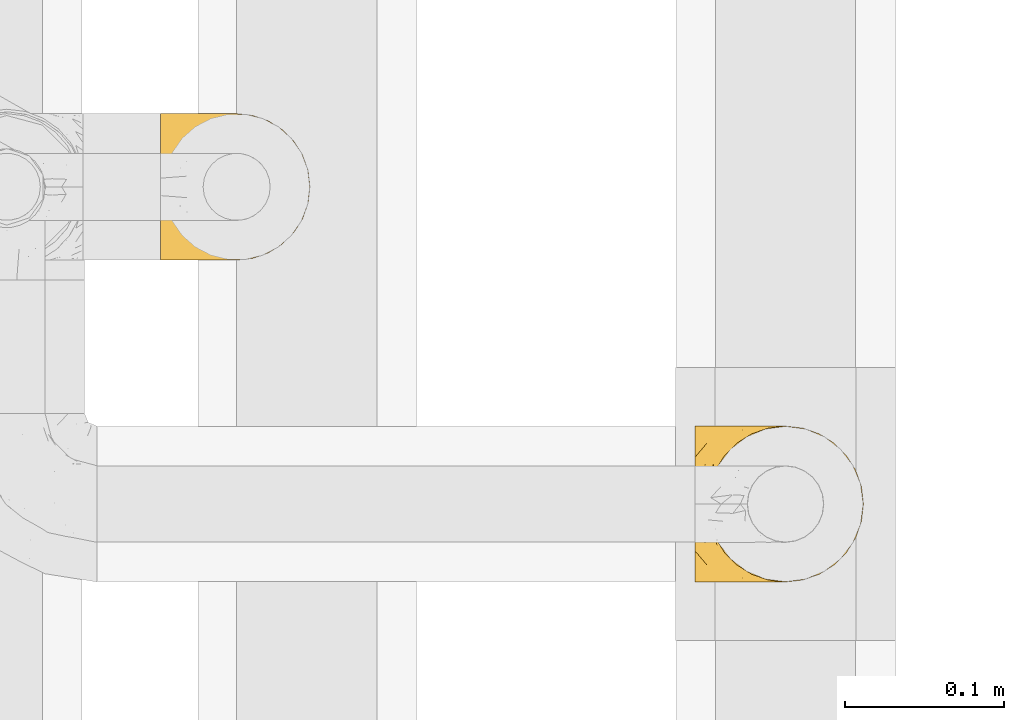
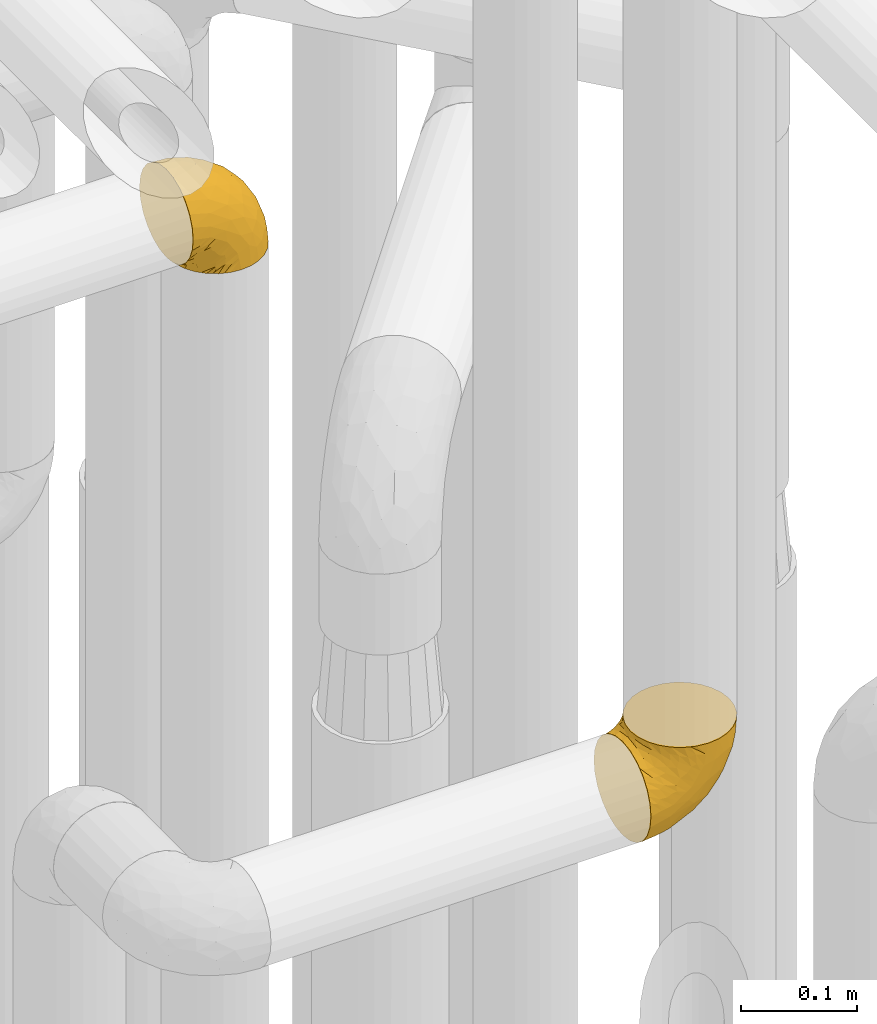
# One storey, part 211 of 827: 2 coverings.
"""IFC2X3 building model written with IfcOpenShell, lengths in millimetres."""

from ifc_helpers import new_model, entity, si_unit, converted_unit, derived_unit, direction, frame, origin, place, context, subcontext, project, spatial, faceted_brep, element, save


model = new_model("IFC2X3")

# Units and contexts
model_context = context("Model", 3, precision=0.01, world=origin(), true_north=direction((6.12303176911189e-17, 1.0)))
body_context = subcontext(model_context, "Body", "Model", "MODEL_VIEW")
ifc_project = project(units=[si_unit("LENGTHUNIT", "METRE", prefix="MILLI"), si_unit("AREAUNIT", "SQUARE_METRE"), si_unit("VOLUMEUNIT", "CUBIC_METRE"), converted_unit("PLANEANGLEUNIT", "DEGREE", entity("IfcRatioMeasure", 0.0174532925199433), si_unit("PLANEANGLEUNIT", "RADIAN"), dimensions=[0, 0, 0, 0, 0, 0, 0]), si_unit("MASSUNIT", "GRAM", prefix="KILO"), derived_unit("MASSDENSITYUNIT", [(si_unit("MASSUNIT", "GRAM", prefix="KILO"), 1), (si_unit("LENGTHUNIT", "METRE"), -3)]), derived_unit("MOMENTOFINERTIAUNIT", [(si_unit("LENGTHUNIT", "METRE"), 4)]), si_unit("TIMEUNIT", "SECOND"), si_unit("FREQUENCYUNIT", "HERTZ"), si_unit("THERMODYNAMICTEMPERATUREUNIT", "DEGREE_CELSIUS"), derived_unit("THERMALTRANSMITTANCEUNIT", [(si_unit("MASSUNIT", "GRAM", prefix="KILO"), 1), (si_unit("THERMODYNAMICTEMPERATUREUNIT", "KELVIN"), -1), (si_unit("TIMEUNIT", "SECOND"), -3)]), derived_unit("VOLUMETRICFLOWRATEUNIT", [(si_unit("LENGTHUNIT", "METRE"), 3), (si_unit("TIMEUNIT", "SECOND"), -1)]), derived_unit("MASSFLOWRATEUNIT", [(si_unit("MASSUNIT", "GRAM", prefix="KILO"), 1), (si_unit("TIMEUNIT", "SECOND"), -1)]), derived_unit("ROTATIONALFREQUENCYUNIT", [(si_unit("TIMEUNIT", "SECOND"), -1)]), si_unit("ELECTRICCURRENTUNIT", "AMPERE"), si_unit("ELECTRICVOLTAGEUNIT", "VOLT"), si_unit("POWERUNIT", "WATT"), si_unit("FORCEUNIT", "NEWTON", prefix="KILO"), si_unit("ILLUMINANCEUNIT", "LUX"), si_unit("LUMINOUSFLUXUNIT", "LUMEN"), si_unit("LUMINOUSINTENSITYUNIT", "CANDELA"), derived_unit("USERDEFINED", [(si_unit("MASSUNIT", "GRAM", prefix="KILO"), -1), (si_unit("LENGTHUNIT", "METRE"), -2), (si_unit("TIMEUNIT", "SECOND"), 3), (si_unit("LUMINOUSFLUXUNIT", "LUMEN"), 1)]), derived_unit("LINEARVELOCITYUNIT", [(si_unit("LENGTHUNIT", "METRE"), 1), (si_unit("TIMEUNIT", "SECOND"), -1)]), si_unit("PRESSUREUNIT", "PASCAL"), derived_unit("USERDEFINED", [(si_unit("LENGTHUNIT", "METRE"), -2), (si_unit("MASSUNIT", "GRAM", prefix="KILO"), 1), (si_unit("TIMEUNIT", "SECOND"), -2)]), derived_unit("LINEARFORCEUNIT", [(si_unit("MASSUNIT", "GRAM", prefix="KILO"), 1), (si_unit("LENGTHUNIT", "METRE"), 1), (si_unit("TIMEUNIT", "SECOND"), -2), (si_unit("LENGTHUNIT", "METRE"), -1)]), derived_unit("PLANARFORCEUNIT", [(si_unit("MASSUNIT", "GRAM", prefix="KILO"), 1), (si_unit("LENGTHUNIT", "METRE"), 1), (si_unit("TIMEUNIT", "SECOND"), -2), (si_unit("LENGTHUNIT", "METRE"), -2)])], contexts=[model_context])

# Site, building, storey
site_placement = place(None, origin())
site = spatial("IfcSite", under=ifc_project, at=site_placement, CompositionType="ELEMENT")
building_placement = place(site_placement, origin())
building = spatial("IfcBuilding", under=site, at=building_placement, CompositionType="ELEMENT")
storey_placement = place(building_placement, frame((0.0, 0.0, 28200.0)))
storey = spatial("IfcBuildingStorey", under=building, at=storey_placement, Name="08", CompositionType="ELEMENT", Elevation=28200.0)

# Coverings
covering_1_placement = place(storey_placement, frame((36161.44, 11305.34, 2549.25)))
element("IfcCovering", 1, at=covering_1_placement, inside=storey, Name=":ADSK_", ObjectType=":ADSK_", PredefinedType="INSULATION", context=body_context, shape_type="Brep", body=[
    faceted_brep([(58.6, 1.6, 107.75), (69.54, 2.83, 107.75), (79.93, 6.47, 107.75), (89.25, 12.32, 107.75), (97.03, 20.11, 107.75), (102.88, 29.43, 107.75), (106.51, 39.81, 107.75), (107.75, 50.75, 107.75), (106.51, 61.69, 107.75), (102.87, 72.08, 107.75), (97.02, 81.4, 107.75), (89.23, 89.18, 107.75), (79.91, 95.03, 107.75), (69.53, 98.66, 107.75), (58.6, 99.9, 107.75), (52.89, 99.25, 107.75), (47.65, 98.66, 107.75), (42.46, 96.84, 107.75), (37.26, 95.02, 107.75), (27.94, 89.17, 107.75), (20.16, 81.38, 107.75), (14.31, 72.06, 107.75), (10.68, 61.68, 107.75), (9.45, 50.75, 107.75), (10.68, 39.8, 107.75), (14.32, 29.41, 107.75), (20.17, 20.09, 107.75), (27.96, 12.31, 107.75), (37.28, 6.46, 107.75), (42.47, 4.64, 107.75), (47.66, 2.83, 107.75), (52.89, 2.24, 107.75), (55.75, 1.92, 107.75), (1.6, 63.47, 98.22), (1.6, 75.32, 93.31), (1.6, 80.41, 89.4), (1.6, 85.5, 85.5), (1.6, 89.4, 80.41), (1.6, 93.31, 75.32), (1.6, 95.77, 69.39), (1.6, 98.22, 63.47), (1.6, 99.14, 56.48), (1.6, 99.52, 53.61), (1.6, 99.9, 50.75), (1.6, 98.22, 38.02), (1.6, 93.31, 26.17), (1.6, 85.5, 15.99), (1.6, 75.32, 8.18), (1.6, 63.47, 3.27), (1.6, 50.75, 1.6), (1.6, 38.02, 3.27), (1.6, 26.17, 8.18), (1.6, 15.99, 15.99), (1.6, 8.18, 26.17), (1.6, 3.27, 38.02), (1.6, 1.6, 50.75), (1.6, 2.35, 56.48), (1.6, 3.27, 63.47), (1.6, 5.73, 69.39), (1.6, 8.18, 75.32), (1.6, 12.09, 80.41), (1.6, 15.99, 85.5), (1.6, 21.08, 89.4), (1.6, 26.17, 93.31), (1.6, 38.02, 98.22), (1.6, 50.75, 99.9), (69.96, 42.18, 27.53), (59.59, 28.42, 25.32), (51.96, 37.78, 16.29), (34.4, 50.75, 6.79), (23.37, 42.85, 4.51), (13.68, 50.75, 3.51), (41.52, 24.75, 17.47), (26.26, 33.81, 7.6), (20.18, 22.57, 12.27), (72.33, 7.18, 70.89), (65.88, 2.73, 87.17), (57.55, 3.09, 67.3), (23.76, 6.92, 31.65), (46.5, 11.58, 33.58), (46.57, 5.17, 47.23), (21.17, 2.71, 43.26), (23.41, 1.6, 55.08), (17.92, 1.6, 53.99), (12.43, 1.6, 52.9), (9.72, 1.6, 52.36), (7.01, 1.6, 51.82), (26.77, 14.18, 21.5), (76.59, 5.88, 89.94), (95.55, 41.06, 60.45), (102.57, 36.25, 83.0), (92.89, 28.62, 64.79), (54.26, 1.6, 85.93), (51.17, 1.6, 81.31), (48.08, 1.6, 76.69), (44.99, 1.6, 72.06), (41.9, 1.6, 67.44), (85.16, 10.85, 88.74), (85.97, 38.35, 45.98), (59.58, 9.6, 47.13), (99.5, 26.24, 89.4), (105.83, 50.75, 95.66), (53.59, 19.31, 28.5), (67.0, 16.41, 42.81), (71.56, 24.56, 38.28), (87.47, 50.75, 45.35), (75.73, 50.75, 33.61), (92.24, 18.47, 82.57), (58.06, 1.6, 105.04), (57.52, 1.6, 102.33), (56.44, 1.6, 96.91), (55.35, 1.6, 91.42), (81.33, 14.36, 65.92), (80.35, 20.64, 53.11), (39.44, 2.32, 54.37), (102.55, 50.75, 74.94), (37.28, 1.6, 64.35), (32.65, 1.6, 61.26), (28.03, 1.6, 58.17), (63.99, 50.75, 21.87), (74.55, 33.88, 34.79), (83.62, 29.24, 48.48), (95.01, 50.75, 60.15), (49.19, 50.75, 14.33), (46.96, 2.8, 99.07), (8.77, 2.48, 60.55), (18.28, 2.7, 64.18), (11.68, 3.2, 64.36), (11.79, 32.98, 103.17), (15.69, 24.67, 101.69), (42.49, 2.95, 87.75), (47.41, 2.19, 89.38), (7.94, 17.92, 88.34), (9.27, 12.02, 82.14), (7.98, 25.73, 94.51), (13.4, 16.63, 89.64), (13.04, 25.6, 98.41), (7.36, 36.72, 99.71), (23.46, 10.66, 89.37), (30.46, 6.87, 88.21), (26.54, 11.12, 95.2), (6.76, 10.31, 79.14), (26.46, 12.84, 101.22), (20.77, 17.38, 99.41), (20.68, 9.74, 84.72), (40.26, 4.63, 97.47), (7.15, 50.75, 102.19), (9.28, 42.52, 104.02), (38.78, 3.12, 82.66), (18.27, 17.58, 95.42), (31.78, 3.97, 78.67), (12.75, 5.94, 72.69), (22.96, 2.73, 66.46), (17.55, 6.23, 75.3), (27.63, 3.45, 72.74), (15.23, 10.84, 82.93), (33.25, 7.98, 99.27), (32.43, 7.33, 93.51), (27.9, 2.39, 67.35), (7.97, 75.76, 94.51), (15.22, 90.65, 82.94), (7.93, 83.57, 88.33), (13.38, 84.85, 89.64), (13.12, 71.05, 103.62), (42.49, 98.54, 87.74), (47.4, 99.3, 89.38), (51.17, 99.9, 81.31), (40.24, 96.86, 97.47), (20.76, 84.1, 99.41), (12.43, 99.9, 52.9), (7.01, 99.9, 51.82), (4.31, 99.9, 51.28), (26.44, 88.63, 101.21), (26.52, 90.36, 95.19), (11.68, 98.29, 64.36), (12.75, 95.55, 72.69), (9.27, 89.47, 82.13), (17.55, 95.26, 75.3), (6.76, 91.18, 79.14), (33.21, 93.49, 99.28), (32.41, 94.15, 93.51), (8.77, 99.01, 60.55), (22.96, 98.76, 66.46), (18.48, 98.85, 63.96), (56.44, 99.9, 96.91), (46.95, 98.69, 99.06), (7.36, 64.78, 99.7), (17.92, 99.9, 53.99), (23.41, 99.9, 55.08), (9.85, 62.91, 103.3), (57.52, 99.9, 102.33), (56.98, 99.9, 99.62), (48.08, 99.9, 76.69), (38.78, 98.37, 82.66), (18.25, 83.9, 95.42), (44.99, 99.9, 72.06), (31.74, 97.51, 78.68), (30.45, 94.62, 88.2), (27.63, 98.04, 72.75), (20.65, 91.73, 84.74), (55.35, 99.9, 91.42), (54.26, 99.9, 85.93), (13.03, 75.87, 98.41), (23.44, 90.83, 89.37), (27.9, 99.1, 67.35), (32.65, 99.9, 61.26), (28.03, 99.9, 58.17), (37.28, 99.9, 64.35), (41.9, 99.9, 67.44), (39.74, 99.09, 54.08), (23.37, 58.64, 4.51), (26.77, 87.31, 21.5), (46.18, 89.93, 33.43), (53.54, 82.22, 28.5), (41.53, 76.74, 17.47), (59.61, 73.12, 25.36), (76.79, 95.54, 90.18), (66.11, 98.7, 86.97), (21.17, 98.79, 43.26), (51.96, 63.71, 16.29), (26.26, 67.68, 7.6), (20.18, 78.92, 12.27), (23.76, 94.57, 31.65), (92.88, 72.88, 64.79), (102.57, 65.25, 83.0), (95.54, 60.44, 60.44), (71.63, 76.94, 38.35), (74.55, 67.61, 34.8), (72.51, 94.38, 71.54), (69.96, 59.31, 27.53), (92.23, 83.03, 82.57), (85.15, 90.66, 88.74), (80.45, 80.8, 53.19), (83.65, 72.22, 48.49), (57.57, 98.39, 67.28), (63.68, 92.31, 52.32), (85.95, 63.11, 45.94), (99.49, 75.27, 89.4), (81.23, 87.15, 65.75), (47.07, 96.03, 46.73), (66.99, 85.1, 42.82)], [[[0, 1, 2, 3, 4, 5, 6, 7, 8, 9, 10, 11, 12, 13, 14, 15, 16, 17, 18, 19, 20, 21, 22, 23, 24, 25, 26, 27, 28, 29, 30, 31, 32]], [[33, 34, 35, 36, 37, 38, 39, 40, 41, 42, 43, 44, 45, 46, 47, 48, 49, 50, 51, 52, 53, 54, 55, 56, 57, 58, 59, 60, 61, 62, 63, 64, 65]], [[66, 67, 68]], [[69, 70, 71]], [[68, 72, 73]], [[73, 72, 74]], [[75, 76, 77]], [[78, 79, 80]], [[51, 50, 73]], [[81, 82, 83, 84, 85, 86, 55]], [[52, 87, 53]], [[74, 52, 51]], [[2, 1, 88]], [[89, 90, 91]], [[77, 92, 93, 94, 95, 96]], [[55, 54, 81]], [[78, 53, 87]], [[5, 90, 6]], [[88, 76, 75]], [[97, 3, 2]], [[89, 91, 98]], [[99, 80, 79]], [[90, 5, 100]], [[74, 87, 52]], [[100, 5, 4]], [[90, 101, 6]], [[79, 102, 103]], [[102, 67, 104]], [[105, 98, 106]], [[107, 4, 3]], [[76, 0, 108, 109, 110, 111, 92]], [[107, 112, 113]], [[114, 77, 96]], [[89, 115, 90]], [[114, 96, 116, 117, 118, 82]], [[75, 97, 88]], [[119, 66, 68]], [[50, 71, 70]], [[100, 91, 90]], [[99, 77, 80]], [[102, 104, 103]], [[97, 107, 3]], [[80, 81, 78]], [[107, 97, 112]], [[68, 73, 70]], [[66, 98, 120]], [[78, 81, 54]], [[114, 81, 80]], [[53, 78, 54]], [[78, 87, 79]], [[102, 87, 72]], [[79, 103, 99]], [[4, 107, 100]], [[91, 100, 107]], [[88, 97, 2]], [[112, 97, 75]], [[99, 112, 75]], [[103, 104, 113]], [[91, 121, 98]], [[89, 105, 122, 115]], [[101, 90, 115]], [[101, 7, 6]], [[88, 1, 76]], [[0, 76, 1]], [[92, 77, 76]], [[73, 74, 51]], [[87, 74, 72]], [[81, 114, 82]], [[77, 114, 80]], [[87, 102, 79]], [[67, 102, 72]], [[68, 67, 72]], [[67, 120, 104]], [[120, 121, 104]], [[104, 121, 113]], [[121, 120, 98]], [[91, 107, 113]], [[91, 113, 121]], [[103, 113, 112]], [[106, 98, 66]], [[105, 89, 98]], [[106, 66, 119]], [[67, 66, 120]], [[68, 69, 123, 119]], [[50, 49, 71]], [[50, 70, 73]], [[112, 99, 103]], [[77, 99, 75]], [[69, 68, 70]], [[29, 124, 110]], [[84, 83, 125]], [[126, 82, 118]], [[59, 58, 127]], [[25, 128, 129]], [[130, 93, 131]], [[132, 62, 133]], [[134, 135, 136]], [[137, 65, 64]], [[64, 134, 137]], [[138, 139, 140]], [[111, 110, 124, 92]], [[134, 136, 137]], [[134, 64, 63]], [[141, 61, 60]], [[125, 58, 57]], [[142, 143, 140]], [[142, 26, 143]], [[127, 83, 82]], [[28, 124, 29]], [[108, 0, 32, 31, 30, 110, 109]], [[30, 29, 110]], [[135, 144, 138]], [[28, 145, 124]], [[57, 56, 55, 86, 85, 84]], [[146, 147, 23]], [[24, 23, 147]], [[25, 143, 26]], [[95, 94, 148]], [[24, 128, 25]], [[149, 138, 143]], [[124, 145, 131]], [[127, 58, 125]], [[150, 148, 139]], [[127, 126, 151]], [[151, 59, 127]], [[152, 151, 126]], [[153, 154, 155]], [[153, 133, 141]], [[145, 28, 27]], [[142, 156, 27]], [[157, 148, 130]], [[61, 133, 62]], [[134, 132, 135]], [[147, 128, 24]], [[65, 137, 146]], [[146, 137, 147]], [[128, 137, 136]], [[137, 128, 147]], [[128, 136, 129]], [[149, 129, 136]], [[25, 129, 143]], [[158, 152, 117]], [[152, 118, 117]], [[153, 151, 152]], [[158, 116, 154]], [[144, 150, 138]], [[153, 152, 158]], [[133, 153, 155]], [[133, 155, 132]], [[60, 151, 141]], [[135, 132, 155]], [[134, 63, 132]], [[144, 135, 155]], [[135, 138, 149]], [[155, 154, 144]], [[150, 154, 96]], [[154, 150, 144]], [[148, 94, 130]], [[82, 126, 127]], [[118, 152, 126]], [[150, 96, 95]], [[139, 148, 157]], [[150, 95, 148]], [[93, 92, 131]], [[130, 145, 156]], [[130, 94, 93]], [[84, 125, 57]], [[127, 125, 83]], [[140, 139, 157]], [[150, 139, 138]], [[140, 157, 142]], [[138, 140, 143]], [[156, 142, 157]], [[27, 26, 142]], [[130, 156, 157]], [[145, 27, 156]], [[132, 63, 62]], [[124, 131, 92]], [[130, 131, 145]], [[129, 149, 143]], [[135, 149, 136]], [[141, 133, 61]], [[60, 59, 151]], [[141, 151, 153]], [[116, 96, 154]], [[153, 158, 154]], [[158, 117, 116]], [[34, 33, 159]], [[160, 161, 162]], [[22, 21, 163]], [[164, 165, 166]], [[19, 18, 167]], [[168, 21, 20]], [[42, 41, 40, 169, 170, 171, 43]], [[172, 173, 168]], [[174, 38, 175]], [[176, 177, 178]], [[179, 164, 180]], [[40, 181, 169]], [[182, 183, 175]], [[17, 184, 185]], [[65, 146, 186]], [[187, 174, 188]], [[23, 22, 189]], [[174, 39, 38]], [[15, 14, 190, 191, 184, 16]], [[181, 40, 39]], [[192, 193, 164]], [[194, 163, 168]], [[33, 186, 159]], [[180, 173, 172]], [[195, 196, 193]], [[18, 185, 167]], [[173, 180, 197]], [[198, 199, 196]], [[200, 201, 185, 184]], [[184, 17, 16]], [[18, 17, 185]], [[202, 159, 186]], [[194, 168, 203]], [[189, 163, 202]], [[204, 205, 182]], [[187, 181, 174]], [[160, 177, 176]], [[206, 183, 182]], [[206, 182, 205]], [[201, 165, 185]], [[165, 164, 167]], [[172, 179, 180]], [[202, 194, 162]], [[176, 161, 160]], [[65, 186, 33]], [[163, 189, 22]], [[175, 177, 182]], [[174, 183, 188]], [[177, 198, 204]], [[199, 160, 162]], [[198, 207, 204]], [[175, 38, 37]], [[198, 177, 160]], [[178, 177, 175]], [[176, 35, 161]], [[34, 159, 161]], [[162, 161, 159]], [[202, 162, 159]], [[199, 162, 203]], [[196, 199, 203]], [[198, 160, 199]], [[193, 197, 180]], [[208, 198, 196]], [[188, 183, 206]], [[175, 183, 174]], [[193, 192, 195]], [[195, 208, 196]], [[197, 196, 203]], [[180, 164, 193]], [[168, 163, 21]], [[166, 165, 201]], [[166, 192, 164]], [[189, 202, 186]], [[186, 146, 189]], [[23, 189, 146]], [[174, 181, 39]], [[169, 181, 187]], [[196, 197, 193]], [[173, 203, 168]], [[203, 173, 197]], [[172, 168, 20]], [[20, 19, 172]], [[179, 172, 19]], [[19, 167, 179]], [[164, 179, 167]], [[35, 176, 36]], [[35, 34, 161]], [[185, 165, 167]], [[162, 194, 203]], [[163, 194, 202]], [[176, 178, 36]], [[37, 36, 178]], [[175, 37, 178]], [[177, 204, 182]], [[207, 198, 208]], [[207, 205, 204]], [[209, 188, 206, 205, 207, 208]], [[48, 210, 71]], [[211, 212, 213]], [[214, 213, 215]], [[216, 217, 13]], [[218, 43, 171, 170, 169, 187, 188]], [[219, 220, 214]], [[47, 46, 221]], [[210, 48, 220]], [[211, 222, 212]], [[222, 45, 44]], [[221, 220, 47]], [[47, 220, 48]], [[221, 211, 214]], [[223, 224, 225]], [[211, 46, 45]], [[226, 227, 215]], [[43, 218, 44]], [[217, 216, 228]], [[219, 215, 229]], [[14, 13, 217]], [[224, 9, 8]], [[10, 230, 11]], [[11, 231, 12]], [[232, 223, 233]], [[234, 208, 195, 192, 166, 201]], [[235, 234, 228]], [[222, 44, 218]], [[106, 229, 236]], [[224, 237, 9]], [[231, 238, 228]], [[9, 237, 10]], [[115, 224, 101]], [[239, 234, 235]], [[231, 11, 230]], [[223, 230, 237]], [[224, 8, 101]], [[223, 236, 233]], [[225, 115, 122, 105]], [[216, 12, 231]], [[209, 234, 239]], [[210, 219, 69]], [[219, 214, 215]], [[229, 119, 219]], [[209, 218, 188]], [[239, 212, 222]], [[239, 222, 218]], [[45, 222, 211]], [[235, 212, 239]], [[213, 212, 240]], [[223, 237, 224]], [[230, 10, 237]], [[238, 231, 230]], [[216, 231, 228]], [[232, 230, 223]], [[235, 238, 240]], [[115, 225, 224]], [[233, 236, 227]], [[8, 7, 101]], [[234, 209, 208]], [[218, 209, 239]], [[217, 228, 234]], [[13, 12, 216]], [[234, 201, 217]], [[217, 201, 200, 184, 191, 190, 14]], [[211, 221, 46]], [[220, 221, 214]], [[71, 210, 69]], [[71, 49, 48]], [[219, 210, 220]], [[226, 215, 213]], [[211, 213, 214]], [[226, 213, 240]], [[215, 227, 229]], [[232, 240, 238]], [[233, 227, 226]], [[232, 233, 226]], [[236, 223, 225]], [[240, 232, 226]], [[232, 238, 230]], [[225, 105, 236]], [[236, 105, 106]], [[236, 229, 227]], [[123, 69, 219, 119]], [[106, 119, 229]], [[238, 235, 228]], [[212, 235, 240]]]),
])
covering_2_placement = place(storey_placement, frame((35824.19, 11508.37, 3150.4)))
element("IfcCovering", 2, at=covering_2_placement, inside=storey, Name=":ADSK_", ObjectType=":ADSK_", PredefinedType="INSULATION", context=body_context, shape_type="Brep", body=[
    faceted_brep([(78.41, 83.91, 1.6), (85.72, 76.59, 1.6), (91.22, 67.83, 1.6), (94.64, 58.07, 1.6), (95.8, 47.8, 1.6), (94.64, 37.51, 1.6), (91.22, 27.74, 1.6), (85.71, 18.98, 1.6), (78.39, 11.67, 1.6), (69.63, 6.17, 1.6), (59.87, 2.75, 1.6), (49.6, 1.6, 1.6), (45.45, 2.06, 1.6), (42.38, 2.41, 1.6), (39.31, 2.75, 1.6), (34.43, 4.46, 1.6), (29.54, 6.17, 1.6), (25.16, 8.93, 1.6), (20.78, 11.68, 1.6), (17.13, 15.34, 1.6), (13.47, 19.0, 1.6), (7.97, 27.76, 1.6), (6.26, 32.64, 1.6), (4.55, 37.52, 1.6), (3.4, 47.8, 1.6), (4.55, 58.08, 1.6), (6.26, 62.96, 1.6), (7.97, 67.85, 1.6), (13.48, 76.61, 1.6), (17.14, 80.26, 1.6), (20.8, 83.92, 1.6), (25.18, 86.67, 1.6), (29.56, 89.42, 1.6), (34.44, 91.13, 1.6), (39.32, 92.84, 1.6), (42.39, 93.18, 1.6), (45.45, 93.53, 1.6), (49.6, 94.0, 1.6), (59.88, 92.84, 1.6), (69.65, 89.42, 1.6), (1.6, 47.8, 3.4), (1.6, 35.84, 4.97), (1.6, 24.7, 9.58), (1.6, 19.91, 13.26), (1.6, 15.13, 16.93), (1.6, 11.46, 21.71), (1.6, 7.78, 26.5), (1.6, 5.48, 32.07), (1.6, 3.17, 37.64), (1.6, 2.69, 41.25), (1.6, 2.42, 43.34), (1.6, 2.14, 45.42), (1.6, 1.6, 49.6), (1.6, 3.17, 61.55), (1.6, 7.78, 72.7), (1.6, 15.13, 82.26), (1.6, 24.7, 89.61), (1.6, 35.84, 94.22), (1.6, 47.8, 95.8), (1.6, 59.75, 94.22), (1.6, 70.9, 89.61), (1.6, 80.46, 82.26), (1.6, 87.81, 72.7), (1.6, 92.42, 61.55), (1.6, 94.0, 49.6), (1.6, 93.45, 45.42), (1.6, 92.9, 41.25), (1.6, 92.42, 37.64), (1.6, 90.11, 32.07), (1.6, 87.81, 26.5), (1.6, 84.13, 21.71), (1.6, 80.46, 16.93), (1.6, 75.68, 13.26), (1.6, 70.9, 9.58), (1.6, 59.75, 4.97), (36.81, 71.98, 81.55), (23.28, 63.6, 90.4), (45.8, 59.72, 83.0), (30.7, 47.8, 91.18), (21.2, 55.16, 93.13), (12.96, 47.8, 94.0), (66.19, 63.76, 66.19), (54.51, 72.22, 70.92), (17.98, 74.18, 85.95), (36.69, 92.52, 49.74), (35.54, 94.0, 35.54), (31.64, 94.0, 38.14), (27.75, 94.0, 40.74), (23.86, 94.0, 43.34), (19.96, 94.0, 45.94), (22.8, 82.14, 77.59), (42.67, 80.34, 71.17), (33.21, 87.52, 65.81), (59.45, 79.59, 59.03), (71.5, 78.25, 45.85), (62.66, 85.01, 45.79), (54.5, 90.25, 41.42), (47.57, 93.2, 34.51), (48.81, 87.23, 56.04), (74.98, 85.55, 15.15), (18.7, 93.0, 56.51), (15.75, 89.31, 68.39), (91.17, 61.31, 23.33), (85.28, 56.86, 42.86), (82.58, 68.34, 39.42), (75.78, 65.71, 53.58), (74.98, 56.99, 59.17), (67.27, 72.15, 59.06), (87.38, 70.34, 22.63), (82.04, 78.36, 20.55), (94.0, 47.8, 12.96), (77.8, 47.8, 56.96), (67.38, 47.8, 67.38), (56.2, 93.06, 18.72), (48.85, 94.0, 5.33), (48.11, 94.0, 9.07), (47.57, 94.0, 11.79), (47.03, 94.0, 14.51), (46.48, 94.0, 17.24), (45.94, 94.0, 19.96), (65.78, 89.88, 21.03), (17.24, 94.0, 46.48), (14.51, 94.0, 47.03), (11.79, 94.0, 47.57), (9.07, 94.0, 48.11), (7.2, 94.0, 48.48), (5.33, 94.0, 48.85), (91.18, 47.8, 30.7), (43.34, 94.0, 23.86), (40.74, 94.0, 27.75), (38.14, 94.0, 31.64), (72.73, 83.7, 31.26), (56.96, 47.8, 77.8), (62.23, 55.9, 72.75), (84.49, 47.8, 43.83), (43.83, 47.8, 84.49), (12.05, 81.75, 14.58), (18.95, 86.43, 16.17), (13.02, 79.8, 10.82), (8.34, 69.84, 4.64), (14.63, 79.5, 7.71), (11.09, 88.08, 25.13), (13.66, 91.6, 32.66), (20.08, 92.93, 34.94), (9.61, 92.43, 36.76), (9.48, 93.24, 40.48), (16.1, 93.36, 39.25), (3.42, 57.25, 3.69), (26.63, 89.41, 13.99), (33.72, 92.89, 21.85), (34.77, 92.66, 17.93), (6.75, 79.58, 15.11), (13.31, 86.51, 21.14), (21.11, 86.29, 12.7), (19.94, 83.91, 7.21), (8.67, 90.94, 32.27), (26.11, 91.94, 25.68), (29.3, 91.98, 22.18), (6.32, 82.79, 18.79), (39.92, 93.16, 10.12), (27.05, 88.76, 9.47), (6.04, 73.94, 10.45), (34.4, 91.89, 11.29), (2.87, 47.8, 2.87), (20.92, 92.22, 31.16), (27.43, 88.56, 6.31), (7.54, 87.72, 25.62), (18.45, 88.33, 21.18), (23.88, 92.18, 28.81), (7.77, 71.78, 7.45), (13.3, 9.09, 21.14), (11.09, 7.51, 25.13), (6.33, 12.8, 18.79), (9.07, 1.6, 48.11), (5.33, 1.6, 48.85), (14.51, 1.6, 47.03), (11.79, 1.6, 47.57), (3.42, 38.35, 3.69), (7.76, 23.84, 7.44), (47.03, 1.6, 14.51), (47.57, 1.6, 11.79), (48.85, 1.6, 5.33), (48.11, 1.6, 9.07), (14.62, 16.1, 7.71), (27.03, 6.84, 9.47), (20.08, 2.66, 34.94), (20.92, 3.37, 31.16), (27.75, 1.6, 40.74), (31.64, 1.6, 38.14), (9.61, 3.16, 36.76), (9.48, 2.35, 40.48), (8.33, 25.77, 4.63), (6.74, 16.02, 15.11), (12.04, 13.85, 14.58), (23.86, 1.6, 43.34), (19.96, 1.6, 45.94), (16.1, 2.23, 39.25), (19.93, 11.69, 7.21), (21.1, 9.31, 12.69), (39.92, 2.43, 10.14), (33.68, 2.71, 21.81), (29.28, 3.61, 22.19), (26.62, 6.18, 14.0), (26.08, 3.66, 25.69), (18.93, 9.17, 16.17), (27.87, 6.77, 6.66), (34.75, 2.93, 17.92), (6.04, 21.66, 10.45), (38.14, 1.6, 31.64), (12.79, 16.09, 10.64), (34.41, 3.7, 11.31), (45.94, 1.6, 19.96), (43.34, 1.6, 23.86), (40.74, 1.6, 27.75), (13.66, 3.99, 32.66), (17.24, 1.6, 46.48), (8.67, 4.65, 32.27), (35.54, 1.6, 35.54), (23.83, 3.43, 28.77), (18.43, 7.27, 21.17), (6.03, 9.46, 23.36), (46.48, 1.6, 17.24), (34.52, 2.4, 47.58), (21.2, 40.43, 93.13), (23.82, 13.57, 77.44), (41.32, 11.3, 66.78), (47.62, 18.65, 71.68), (52.66, 27.26, 74.96), (36.81, 23.61, 81.55), (49.75, 3.07, 36.7), (19.07, 2.69, 56.9), (45.8, 35.87, 83.0), (23.28, 31.99, 90.4), (21.35, 6.71, 67.83), (17.98, 21.41, 85.95), (82.57, 27.24, 39.41), (91.17, 34.26, 23.33), (85.27, 38.73, 42.87), (73.89, 26.97, 53.92), (66.19, 31.83, 66.19), (62.43, 23.4, 64.12), (63.53, 6.91, 33.13), (58.45, 3.4, 23.1), (67.16, 5.84, 16.98), (62.22, 39.69, 72.75), (81.54, 17.6, 23.77), (74.8, 10.38, 18.41), (75.83, 20.6, 43.7), (41.45, 5.36, 54.53), (76.72, 35.73, 55.72), (88.2, 24.84, 17.73), (71.6, 13.87, 38.98), (56.23, 9.06, 50.28), (59.44, 15.99, 59.02)], [[[0, 1, 2, 3, 4, 5, 6, 7, 8, 9, 10, 11, 12, 13, 14, 15, 16, 17, 18, 19, 20, 21, 22, 23, 24, 25, 26, 27, 28, 29, 30, 31, 32, 33, 34, 35, 36, 37, 38, 39]], [[40, 41, 42, 43, 44, 45, 46, 47, 48, 49, 50, 51, 52, 53, 54, 55, 56, 57, 58, 59, 60, 61, 62, 63, 64, 65, 66, 67, 68, 69, 70, 71, 72, 73, 74]], [[75, 76, 77]], [[78, 79, 80]], [[77, 81, 82]], [[76, 75, 83]], [[84, 85, 86, 87, 88, 89]], [[90, 91, 92]], [[76, 60, 59]], [[93, 94, 95]], [[90, 62, 61]], [[83, 61, 60]], [[96, 97, 84]], [[98, 93, 95]], [[0, 39, 99]], [[100, 84, 89]], [[62, 101, 63]], [[2, 102, 3]], [[92, 84, 100]], [[103, 102, 104]], [[103, 105, 106]], [[93, 107, 94]], [[1, 108, 2]], [[92, 101, 90]], [[108, 1, 109]], [[102, 110, 3]], [[93, 82, 107]], [[102, 108, 104]], [[111, 106, 112]], [[109, 0, 99]], [[113, 37, 114, 115, 116, 117, 118, 119]], [[120, 38, 113]], [[100, 89, 121, 122, 123, 124, 125, 126, 64]], [[127, 102, 103]], [[97, 119, 128, 129, 130, 85]], [[99, 120, 131]], [[132, 133, 77]], [[59, 80, 79]], [[1, 0, 109]], [[98, 84, 92]], [[94, 109, 131]], [[120, 39, 38]], [[93, 91, 82]], [[104, 94, 105]], [[97, 113, 119]], [[95, 120, 96]], [[83, 90, 61]], [[91, 93, 98]], [[64, 63, 100]], [[100, 63, 101]], [[77, 76, 79]], [[133, 106, 81]], [[84, 97, 85]], [[113, 96, 120]], [[113, 97, 96]], [[37, 113, 38]], [[110, 102, 127]], [[110, 4, 3]], [[103, 111, 134, 127]], [[90, 75, 91]], [[82, 81, 107]], [[91, 75, 82]], [[77, 82, 75]], [[76, 83, 60]], [[90, 83, 75]], [[105, 107, 81]], [[94, 131, 95]], [[105, 94, 107]], [[109, 94, 104]], [[120, 95, 131]], [[98, 95, 96]], [[84, 98, 96]], [[98, 92, 91]], [[106, 105, 81]], [[103, 104, 105]], [[112, 106, 133]], [[103, 106, 111]], [[112, 133, 132]], [[81, 77, 133]], [[77, 78, 135, 132]], [[120, 99, 39]], [[109, 99, 131]], [[59, 58, 80]], [[59, 79, 76]], [[90, 101, 62]], [[100, 101, 92]], [[2, 108, 102]], [[109, 104, 108]], [[78, 77, 79]], [[136, 137, 138]], [[27, 139, 140]], [[141, 142, 143]], [[144, 145, 121]], [[146, 89, 88]], [[147, 139, 25]], [[148, 149, 150]], [[136, 151, 152]], [[147, 40, 74]], [[24, 147, 25]], [[140, 153, 154]], [[33, 116, 34]], [[73, 72, 151]], [[114, 37, 36, 35, 34, 116, 115]], [[146, 155, 144]], [[156, 85, 130]], [[157, 149, 148]], [[151, 158, 152]], [[117, 33, 159]], [[29, 154, 160]], [[161, 74, 73]], [[162, 128, 119]], [[66, 65, 64, 126, 125, 124, 123, 122, 67]], [[163, 147, 24]], [[27, 140, 28]], [[149, 129, 150]], [[139, 27, 26, 25]], [[68, 144, 69]], [[129, 128, 150]], [[164, 87, 86]], [[130, 129, 149]], [[122, 145, 67]], [[154, 153, 148]], [[162, 119, 159]], [[165, 30, 160]], [[150, 160, 148]], [[128, 162, 150]], [[30, 165, 31]], [[145, 144, 68]], [[89, 146, 144]], [[87, 164, 143]], [[166, 155, 142]], [[88, 87, 143]], [[162, 160, 150]], [[160, 30, 29]], [[154, 29, 28]], [[140, 154, 28]], [[160, 154, 148]], [[140, 137, 153]], [[157, 148, 153]], [[156, 130, 157]], [[153, 137, 157]], [[157, 137, 156]], [[167, 137, 136]], [[168, 85, 156]], [[152, 168, 167]], [[167, 168, 156]], [[164, 152, 141]], [[71, 158, 72]], [[152, 167, 136]], [[88, 142, 146]], [[144, 155, 69]], [[146, 142, 155]], [[70, 166, 71]], [[142, 141, 166]], [[70, 69, 155]], [[141, 158, 71]], [[161, 73, 151]], [[138, 137, 140]], [[161, 136, 169]], [[136, 161, 151]], [[74, 161, 169]], [[152, 158, 141]], [[151, 72, 158]], [[168, 152, 164]], [[137, 167, 156]], [[164, 86, 168]], [[85, 168, 86]], [[116, 33, 117]], [[130, 149, 157]], [[67, 145, 68]], [[121, 89, 144]], [[145, 122, 121]], [[40, 147, 163]], [[169, 147, 74]], [[159, 33, 32]], [[162, 159, 32]], [[159, 119, 118, 117]], [[139, 147, 169]], [[139, 169, 138]], [[162, 32, 31]], [[141, 143, 164]], [[88, 143, 142]], [[71, 166, 141]], [[155, 166, 70]], [[139, 138, 140]], [[169, 136, 138]], [[160, 162, 165]], [[162, 31, 165]], [[170, 171, 172]], [[173, 174, 52, 51, 50, 49, 48, 175, 176]], [[177, 178, 41]], [[179, 15, 180]], [[12, 11, 181, 182, 180, 14, 13]], [[183, 21, 20]], [[19, 18, 184]], [[185, 186, 187]], [[186, 188, 187]], [[43, 172, 44]], [[189, 190, 47]], [[23, 22, 21, 191]], [[170, 192, 193]], [[40, 163, 177]], [[194, 195, 196]], [[24, 23, 177]], [[197, 198, 183]], [[199, 15, 179]], [[47, 46, 189]], [[200, 201, 202]], [[201, 203, 204]], [[205, 206, 184]], [[207, 41, 178]], [[16, 15, 199]], [[14, 180, 15]], [[202, 201, 198]], [[208, 201, 200]], [[163, 24, 177]], [[48, 47, 190]], [[196, 195, 189]], [[197, 184, 202]], [[204, 193, 209]], [[210, 211, 212]], [[206, 212, 213]], [[205, 17, 210]], [[184, 206, 202]], [[210, 212, 206]], [[185, 194, 214]], [[189, 215, 190]], [[216, 45, 214]], [[186, 171, 170]], [[189, 216, 196]], [[197, 20, 19]], [[194, 185, 187]], [[197, 183, 20]], [[184, 197, 19]], [[197, 202, 198]], [[206, 200, 202]], [[204, 183, 198]], [[201, 208, 203]], [[203, 208, 217]], [[204, 198, 201]], [[217, 188, 218]], [[193, 219, 170]], [[171, 186, 185]], [[170, 218, 186]], [[170, 219, 218]], [[42, 207, 192]], [[171, 220, 172]], [[216, 189, 46]], [[214, 194, 196]], [[44, 220, 45]], [[214, 196, 216]], [[216, 46, 45]], [[214, 45, 220]], [[192, 43, 42]], [[204, 203, 219]], [[207, 193, 192]], [[209, 193, 178]], [[41, 207, 42]], [[193, 207, 178]], [[43, 192, 172]], [[170, 172, 192]], [[204, 219, 193]], [[219, 203, 218]], [[217, 218, 203]], [[188, 186, 218]], [[206, 213, 200]], [[208, 200, 213]], [[199, 210, 16]], [[215, 189, 195]], [[215, 175, 190]], [[175, 48, 190]], [[199, 179, 221, 211]], [[210, 199, 211]], [[23, 191, 177]], [[40, 177, 41]], [[178, 177, 191]], [[21, 183, 191]], [[209, 191, 183]], [[205, 18, 17]], [[17, 16, 210]], [[171, 185, 214]], [[172, 220, 44]], [[214, 220, 171]], [[191, 209, 178]], [[204, 209, 183]], [[206, 205, 210]], [[18, 205, 184]], [[222, 195, 194, 187, 188, 217]], [[57, 223, 80]], [[224, 225, 226]], [[226, 227, 228]], [[229, 217, 208, 213, 212, 211]], [[230, 52, 174, 173, 176, 175, 215, 195]], [[231, 232, 228]], [[231, 78, 223]], [[223, 57, 232]], [[224, 233, 225]], [[233, 54, 53]], [[234, 232, 56]], [[56, 55, 234]], [[234, 224, 228]], [[235, 236, 237]], [[224, 55, 54]], [[238, 239, 240]], [[52, 230, 53]], [[241, 242, 243]], [[227, 244, 231]], [[11, 10, 242]], [[236, 6, 5]], [[7, 245, 8]], [[8, 246, 9]], [[238, 247, 235]], [[222, 229, 248]], [[242, 211, 221, 179, 180, 182, 181, 11]], [[233, 53, 230]], [[111, 112, 249]], [[250, 6, 236]], [[246, 251, 241]], [[6, 250, 7]], [[127, 236, 110]], [[248, 229, 252]], [[246, 8, 245]], [[235, 245, 250]], [[236, 5, 110]], [[235, 249, 238]], [[237, 236, 127]], [[243, 9, 246]], [[252, 229, 241]], [[56, 232, 57]], [[222, 230, 195]], [[225, 248, 252]], [[248, 233, 230]], [[54, 233, 224]], [[231, 228, 227]], [[244, 132, 231]], [[248, 225, 233]], [[226, 225, 253]], [[235, 250, 236]], [[245, 7, 250]], [[251, 246, 245]], [[243, 246, 241]], [[247, 245, 235]], [[252, 251, 253]], [[229, 222, 217]], [[230, 222, 248]], [[5, 4, 110]], [[237, 127, 134, 111]], [[238, 249, 239]], [[224, 234, 55]], [[232, 234, 228]], [[242, 241, 229]], [[10, 9, 243]], [[211, 242, 229]], [[10, 243, 242]], [[80, 223, 78]], [[80, 58, 57]], [[231, 223, 232]], [[227, 240, 239]], [[224, 226, 228]], [[240, 226, 253]], [[227, 239, 244]], [[226, 240, 227]], [[251, 247, 253]], [[240, 253, 247]], [[249, 235, 237]], [[237, 111, 249]], [[112, 132, 244]], [[112, 244, 249]], [[78, 231, 132, 135]], [[249, 244, 239]], [[247, 238, 240]], [[245, 247, 251]], [[251, 252, 241]], [[225, 252, 253]]]),
])

save(model, "model.ifc")
